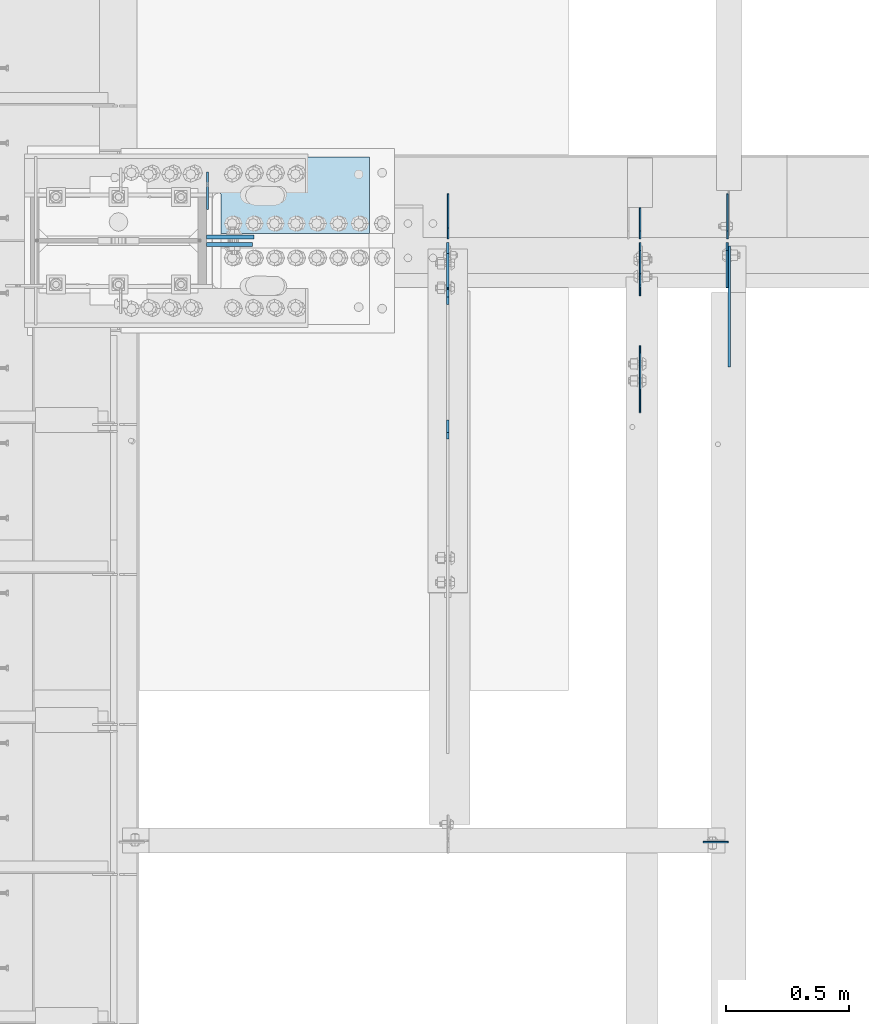
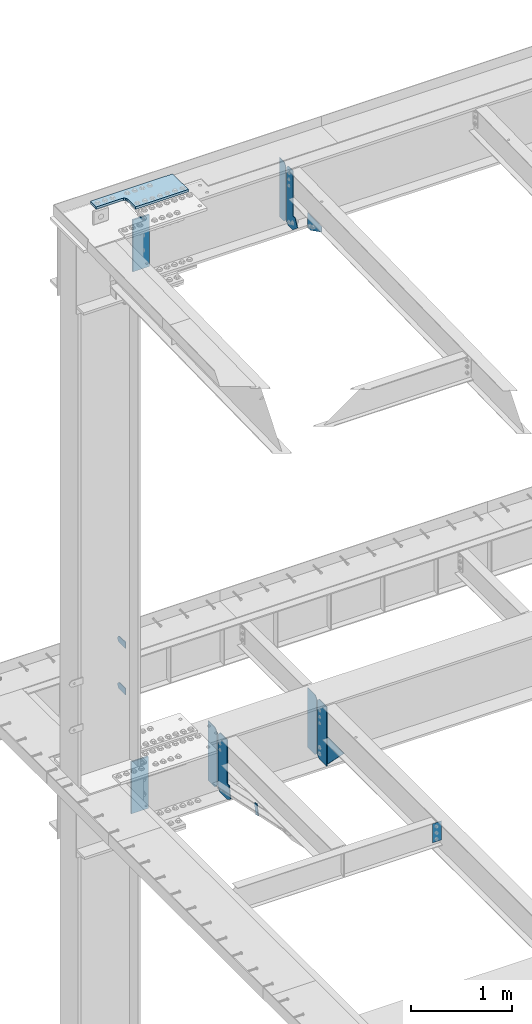
# One storey, part 1597 of 1763: 15 plates, 7 elements without a shape of their own.
"""IFC2X3 building model written with IfcOpenShell, lengths in millimetres."""

from ifc_helpers import new_model, si_unit, frame, origin_with_axes, place, context, subcontext, project, spatial, faceted_brep, material, type_object, element, aggregate, save


model = new_model("IFC2X3")

# Units and contexts
model_context = context("Model", 3, precision=1e-05, world=origin_with_axes())
body_context = subcontext(model_context, "Body", "Model", "MODEL_VIEW")
ifc_project = project(units=[si_unit("LENGTHUNIT", "METRE", prefix="MILLI"), si_unit("AREAUNIT", "SQUARE_METRE"), si_unit("VOLUMEUNIT", "CUBIC_METRE"), si_unit("MASSUNIT", "GRAM", prefix="KILO"), si_unit("TIMEUNIT", "SECOND"), si_unit("PLANEANGLEUNIT", "RADIAN"), si_unit("SOLIDANGLEUNIT", "STERADIAN"), si_unit("THERMODYNAMICTEMPERATUREUNIT", "DEGREE_CELSIUS"), si_unit("LUMINOUSINTENSITYUNIT", "LUMEN")], contexts=[model_context])

# Site, building, storey
site_placement = place(None, origin_with_axes())
site = spatial("IfcSite", under=ifc_project, at=site_placement, CompositionType="ELEMENT")
building_placement = place(site_placement, origin_with_axes())
building = spatial("IfcBuilding", under=site, at=building_placement, Name="Undefined", CompositionType="ELEMENT")
storey_placement = place(building_placement, origin_with_axes())
storey = spatial("IfcBuildingStorey", under=building, at=storey_placement, Name="Undefined", CompositionType="ELEMENT", Elevation=0.0)

# Assembly, plates
assembly_1_placement = place(storey_placement, origin_with_axes())
assembly_1 = element("IfcElementAssembly", 1, at=assembly_1_placement, inside=storey, Name="COLUMN", AssemblyPlace="NOTDEFINED", PredefinedType="RIGID_FRAME")
ifc_material_1 = material(Name="STEEL/A36")
plate_type_1 = type_object("IfcPlateType", PredefinedType="NOTDEFINED")
plate_1_placement = place(assembly_1_placement, frame((-87013.4872736984, 52247.8, 6489.69999847412), z_axis=(0.0, 0.0, -1.0), x_axis=(0.0, 1.0, 0.0)))
plate_1 = element("IfcPlate", 2, at=plate_1_placement, type_object=plate_type_1, material=ifc_material_1, Name="PLATE", context=body_context, shape_type="Brep", body=[
    faceted_brep([(0.0, -4.76249999999982, 0.0), (0.0, -4.76250000000073, 76.1999969482422), (0.0, 4.76250000000073, 76.1999969482422), (0.0, 4.76249999999982, 0.0), (114.299995422363, -4.76250000000073, 76.1999969482422), (114.299995422363, 4.76250000000073, 76.1999969482422), (126.073542436527, -4.76250000000073, 74.3352502937696), (126.073542436527, 4.76250000000073, 74.3352502937696), (136.694612637817, -4.76250000000073, 68.923544725345), (136.694612637817, 4.76250000000073, 68.923544725345), (145.123541673587, -4.76250000000073, 60.4946156895749), (145.123541673587, 4.76250000000073, 60.4946156895749), (150.535247242013, -4.76250000000073, 49.8735454882844), (150.535247242013, 4.76250000000073, 49.8735454882844), (152.399993896484, -4.76250000000073, 38.0999984741211), (152.399993896484, 4.76250000000073, 38.0999984741211), (150.535247242013, -4.76250000000073, 26.3264514599578), (150.535247242013, 4.76250000000073, 26.3264514599578), (145.123541673587, -4.76250000000073, 15.7053812586673), (145.123541673587, 4.76250000000073, 15.7053812586673), (136.694612637817, -4.76250000000073, 7.27645222289721), (136.694612637817, 4.76250000000073, 7.27645222289721), (126.073542436527, -4.76250000000073, 1.86474665447258), (126.073542436527, 4.76250000000073, 1.86474665447258), (114.299995422363, -4.76250000000073, 0.0), (114.299995422363, 4.76250000000073, 0.0)], [[[0, 1, 2, 3]], [[1, 4, 5, 2]], [[4, 6, 7, 5]], [[6, 8, 9, 7]], [[8, 10, 11, 9]], [[10, 12, 13, 11]], [[12, 14, 15, 13]], [[14, 16, 17, 15]], [[16, 18, 19, 17]], [[18, 20, 21, 19]], [[20, 22, 23, 21]], [[22, 24, 25, 23]], [[24, 0, 3, 25]], [[5, 7, 9, 11, 13, 15, 17, 19, 21, 23, 25, 3, 2]], [[24, 22, 20, 18, 16, 14, 12, 10, 8, 6, 4, 1, 0]]]),
])
plate_2_placement = place(assembly_1_placement, frame((-87013.4872736984, 52247.8, 5930.89999847412), z_axis=(0.0, 0.0, -1.0), x_axis=(0.0, 1.0, 0.0)))
plate_2 = element("IfcPlate", 3, at=plate_2_placement, type_object=plate_type_1, material=ifc_material_1, Name="PLATE", context=body_context, shape_type="Brep", body=[
    faceted_brep([(0.0, -4.76249999999982, 0.0), (0.0, -4.76250000000073, 76.1999969482422), (0.0, 4.76250000000073, 76.1999969482422), (0.0, 4.76249999999982, 0.0), (114.299995422363, -4.76250000000073, 76.1999969482422), (114.299995422363, 4.76250000000073, 76.1999969482422), (126.073542436527, -4.76250000000073, 74.3352502937696), (126.073542436527, 4.76250000000073, 74.3352502937696), (136.694612637817, -4.76250000000073, 68.923544725345), (136.694612637817, 4.76250000000073, 68.923544725345), (145.123541673587, -4.76250000000073, 60.4946156895749), (145.123541673587, 4.76250000000073, 60.4946156895749), (150.535247242013, -4.76250000000073, 49.8735454882844), (150.535247242013, 4.76250000000073, 49.8735454882844), (152.399993896484, -4.76250000000073, 38.0999984741211), (152.399993896484, 4.76250000000073, 38.0999984741211), (150.535247242013, -4.76250000000073, 26.3264514599578), (150.535247242013, 4.76250000000073, 26.3264514599578), (145.123541673587, -4.76250000000073, 15.7053812586673), (145.123541673587, 4.76250000000073, 15.7053812586673), (136.694612637817, -4.76250000000073, 7.27645222289721), (136.694612637817, 4.76250000000073, 7.27645222289721), (126.073542436527, -4.76250000000073, 1.86474665447258), (126.073542436527, 4.76250000000073, 1.86474665447258), (114.299995422363, -4.76250000000073, 0.0), (114.299995422363, 4.76250000000073, 0.0)], [[[0, 1, 2, 3]], [[1, 4, 5, 2]], [[4, 6, 7, 5]], [[6, 8, 9, 7]], [[8, 10, 11, 9]], [[10, 12, 13, 11]], [[12, 14, 15, 13]], [[14, 16, 17, 15]], [[16, 18, 19, 17]], [[18, 20, 21, 19]], [[20, 22, 23, 21]], [[22, 24, 25, 23]], [[24, 0, 3, 25]], [[5, 7, 9, 11, 13, 15, 17, 19, 21, 23, 25, 3, 2]], [[24, 22, 20, 18, 16, 14, 12, 10, 8, 6, 4, 1, 0]]]),
])

# Assembly, plate
assembly_2_placement = place(storey_placement, origin_with_axes())
assembly_2 = element("IfcElementAssembly", 4, at=assembly_2_placement, inside=storey, Name="ANGLE BRACE", AssemblyPlace="NOTDEFINED", PredefinedType="RIGID_FRAME")
plate_type_2 = type_object("IfcPlateType", PredefinedType="NOTDEFINED")
plate_3_placement = place(assembly_2_placement, frame((-86037.1747736983, 51342.4281032895, 4746.91590772782), z_axis=(0.0, -0.208168683014592, -0.978092940068566), x_axis=(0.0, 0.978092940068566, -0.208168683014588)))
plate_3 = element("IfcPlate", 5, at=plate_3_placement, type_object=plate_type_2, material=ifc_material_1, Name="PLATE", context=body_context, shape_type="Brep", body=[
    faceted_brep([(0.0, -4.76249999999982, 0.0), (2.11002770811319e-09, -4.76249999999709, 127.040328979458), (2.11002770811319e-09, 4.76249999999709, 127.040328979458), (0.0, 4.76249999999982, 0.0), (50.7119293213109, -4.76249999999709, 126.999992370584), (50.7119293213109, 4.76249999999709, 126.999992370584), (50.7119293211581, -4.76249999999709, 1.63709046319127e-11), (50.7119293211581, 4.76249999999709, 1.63709046319127e-11)], [[[0, 1, 2, 3]], [[1, 4, 5, 2]], [[4, 6, 7, 5]], [[6, 0, 3, 7]], [[5, 7, 3, 2]], [[6, 4, 1, 0]]]),
])
aggregate(assembly_2, [plate_3])

assembly_3_placement = place(storey_placement, origin_with_axes())
assembly_3 = element("IfcElementAssembly", 6, at=assembly_3_placement, inside=storey, Name="BEAM", AssemblyPlace="NOTDEFINED", PredefinedType="RIGID_FRAME")
plate_type_3 = type_object("IfcPlateType", PredefinedType="NOTDEFINED")
plate_4_placement = place(assembly_3_placement, frame((-84897.878940365, 49676.84375, 5156.2), z_axis=(-1.0, 0.0, 0.0), x_axis=(0.0, 0.0, -1.0)))
plate_4 = element("IfcPlate", 7, at=plate_4_placement, type_object=plate_type_3, material=ifc_material_1, Name="PLATE", context=body_context, shape_type="Brep", body=[
    faceted_brep([(1.81898940354586e-12, -3.17500000000291, 0.0), (0.0, -3.17499999999927, 101.599998474121), (0.0, 3.17499999999927, 101.599998474121), (-1.81898940354586e-12, 3.17499999997381, 0.0), (228.600006103516, -3.17499999999927, 101.599998474121), (228.600006103516, 3.17499999999927, 101.599998474121), (228.600006103516, -3.17500000001019, -7.27595761418343e-12), (228.600006103516, 3.17499999999563, -7.27595761418343e-12)], [[[0, 1, 2, 3]], [[1, 4, 5, 2]], [[4, 6, 7, 5]], [[6, 0, 3, 7]], [[5, 7, 3, 2]], [[6, 4, 1, 0]]]),
])

assembly_4_placement = place(storey_placement, origin_with_axes())
assembly_4 = element("IfcElementAssembly", 8, at=assembly_4_placement, inside=storey, Name="BEAM", AssemblyPlace="NOTDEFINED", PredefinedType="RIGID_FRAME")
plate_type_4 = type_object("IfcPlateType", PredefinedType="NOTDEFINED")
plate_5_placement = place(assembly_4_placement, frame((-85255.4444166032, 52128.7375017387, 11001.3749917654), z_axis=(0.0, 0.0, 1.0), x_axis=(0.0, 1.0, 0.0)))
plate_5 = element("IfcPlate", 9, at=plate_5_placement, type_object=plate_type_4, material=ifc_material_1, Name="PLATE", context=body_context, shape_type="Brep", body=[
    faceted_brep([(0.0, -3.17500000000291, 31.75), (0.0, -3.17500000000291, 682.625), (0.0, 3.17500000000291, 682.625), (0.0, 3.17500000000291, 31.75), (31.75, -3.17500000000291, 714.375), (31.75, 3.17500000000291, 714.375), (125.412498474121, -3.17500000000291, 714.375), (125.412498474121, 3.17500000000291, 714.375), (125.412498474121, -3.17500000000291, 0.0), (125.412498474121, 3.17500000000291, 0.0), (31.7499999999036, -3.17499999997381, 9.42916855706244e-11), (31.7499999998854, 3.17500000000291, 9.42916855706244e-11)], [[[0, 1, 2, 3]], [[1, 4, 5, 2]], [[4, 6, 7, 5]], [[6, 8, 9, 7]], [[8, 10, 11, 9]], [[10, 0, 3, 11]], [[5, 7, 9, 11, 3, 2]], [[10, 8, 6, 4, 1, 0]]]),
])

# Assembly, plates
assembly_5_placement = place(storey_placement, origin_with_axes())
assembly_5 = element("IfcElementAssembly", 10, at=assembly_5_placement, inside=storey, Name="BEAM", AssemblyPlace="NOTDEFINED", PredefinedType="RIGID_FRAME")
plate_type_5 = type_object("IfcPlateType", PredefinedType="NOTDEFINED")
plate_6_placement = place(assembly_5_placement, frame((-84901.0539404127, 52128.7375, 4448.175), z_axis=(0.0, 0.0, 1.0), x_axis=(0.0, 1.0, 0.0)))
plate_6 = element("IfcPlate", 11, at=plate_6_placement, type_object=plate_type_5, material=ifc_material_1, Name="PLATE", context=body_context, shape_type="Brep", body=[
    faceted_brep([(0.0, -3.17500000000291, 31.75), (0.0, -3.17500000000291, 687.387512207031), (0.0, 3.17500000000291, 687.387512207031), (0.0, 3.17500000000291, 31.75), (31.75, -3.17500000000291, 719.137512207031), (31.75, 3.17500000000291, 719.137512207031), (182.5625, -3.17500000000291, 719.137512207031), (182.5625, 3.17500000000291, 719.137512207031), (182.5625, -3.17500000000291, 0.0), (182.5625, 3.17500000000291, 0.0), (31.7499999999036, -3.17499999997381, 9.42916855706244e-11), (31.7499999998854, 3.17500000000291, 9.42916855706244e-11)], [[[0, 1, 2, 3]], [[1, 4, 5, 2]], [[4, 6, 7, 5]], [[6, 8, 9, 7]], [[8, 10, 11, 9]], [[10, 0, 3, 11]], [[5, 7, 9, 11, 3, 2]], [[10, 8, 6, 4, 1, 0]]]),
])
plate_7_placement = place(assembly_5_placement, frame((-86035.587273746, 52128.7375, 4448.175), z_axis=(0.0, 0.0, 1.0), x_axis=(0.0, 1.0, 0.0)))
plate_7 = element("IfcPlate", 12, at=plate_7_placement, type_object=plate_type_5, material=ifc_material_1, Name="PLATE", context=body_context, shape_type="Brep", body=[
    faceted_brep([(0.0, -3.17500000000291, 44.4500000000007), (0.0, -3.17500000000291, 673.099987030029), (0.0, 3.17500000000291, 673.099987030029), (0.0, 3.17500000000291, 44.4500000000007), (44.4500007629395, -3.17500000000291, 717.549987792969), (44.4500007629395, 3.17500000000291, 717.549987792969), (182.5625, -3.17500000000291, 717.549987792969), (182.5625, 3.17500000000291, 717.549987792969), (182.5625, -3.17500000000291, 0.0), (182.5625, 3.17500000000291, 0.0), (44.4500007629395, -3.17500000000291, 0.0), (44.4500007629395, 3.17500000000291, 0.0)], [[[0, 1, 2, 3]], [[1, 4, 5, 2]], [[4, 6, 7, 5]], [[6, 8, 9, 7]], [[8, 10, 11, 9]], [[10, 0, 3, 11]], [[5, 7, 9, 11, 3, 2]], [[10, 8, 6, 4, 1, 0]]]),
])
plate_type_6 = type_object("IfcPlateType", PredefinedType="NOTDEFINED")
plate_8_placement = place(assembly_5_placement, frame((-84901.8486904299, 52112.8625, 4448.175), z_axis=(0.0, 0.0, 1.0), x_axis=(0.0, -1.0, 0.0)))
plate_8 = element("IfcPlate", 13, at=plate_8_placement, type_object=plate_type_6, material=ifc_material_1, Name="PLATE", context=body_context, shape_type="Brep", body=[
    faceted_brep([(0.0, -3.96899999999732, 31.75), (0.0, -3.96899999999732, 687.387512207031), (0.0, 3.96899999999732, 687.387512207031), (0.0, 3.96899999999732, 31.75), (31.75, -3.96899999999732, 719.137512207031), (31.75, 3.96899999999732, 719.137512207031), (182.5625, -3.96899999999732, 719.137512207031), (182.5625, 3.96899999999732, 719.137512207031), (182.5625, -3.96899999999732, 0.0), (182.5625, 3.96899999999732, 0.0), (31.75, -3.96899999999732, 0.0), (31.75, 3.96899999999732, 0.0)], [[[0, 1, 2, 3]], [[1, 4, 5, 2]], [[4, 6, 7, 5]], [[6, 8, 9, 7]], [[8, 10, 11, 9]], [[10, 0, 3, 11]], [[5, 7, 9, 11, 3, 2]], [[10, 8, 6, 4, 1, 0]]]),
])

# Plate
plate_type_7 = type_object("IfcPlateType", PredefinedType="NOTDEFINED")
plate_9_placement = place(assembly_3_placement, frame((-84893.1164404127, 51930.3004272461, 4794.2499684514), z_axis=(0.0, 0.0, -1.0), x_axis=(0.0, -1.0, 0.0)))
plate_9 = element("IfcPlate", 14, at=plate_9_placement, type_object=plate_type_7, material=ifc_material_1, Name="PLATE", context=body_context, shape_type="Brep", body=[
    faceted_brep([(0.0, -4.76249999999982, 0.0), (-169.862075805664, -4.76249999999709, 6.30279828328639e-10), (-169.862075805664, 4.76249999999709, 6.30279828328639e-10), (0.0, 4.76249999999982, 0.0), (-169.862091064453, -4.76249999999709, 323.002471923828), (-169.862091064453, 4.76249999999709, 323.002471923828), (6.38101482763886e-09, -4.76249999999709, 323.002471923828), (6.38101482763886e-09, 4.76249999999709, 323.002471923828), (322.262145996094, -4.76249999999709, -1.15778675535694e-09), (322.262145996094, 4.76249999999709, -1.15778675535694e-09)], [[[0, 1, 2, 3]], [[1, 4, 5, 2]], [[4, 6, 7, 5]], [[6, 8, 9, 7]], [[8, 0, 3, 9]], [[5, 7, 9, 3, 2]], [[8, 6, 4, 1, 0]]]),
])

aggregate(assembly_3, [plate_9, plate_4])

ifc_material_2 = material(Name="STEEL/A572-50")
plate_type_8 = type_object("IfcPlateType", PredefinedType="NOTDEFINED")
plate_10_placement = place(assembly_1_placement, frame((-86830.9247736984, 52104.9250002128, 11045.8249917654), z_axis=(-1.0, 0.0, 0.0), x_axis=(0.0, 0.0, 1.0)))
plate_10 = element("IfcPlate", 15, at=plate_10_placement, type_object=plate_type_8, material=ifc_material_2, Name="SHEAR TAB", context=body_context, shape_type="Brep", body=[
    faceted_brep([(-7.27595761418343e-12, -7.9375, 0.0), (0.0, -7.9375, 187.324996948242), (0.0, 7.9375, 187.324996948242), (-7.27595761418343e-12, 7.9375, 0.0), (625.474975585938, -7.9375, 187.324996948242), (625.474975585938, 7.9375, 187.324996948242), (625.474975585938, -7.9375, 0.0), (625.474975585938, 7.9375, 0.0)], [[[0, 1, 2, 3]], [[1, 4, 5, 2]], [[4, 6, 7, 5]], [[6, 0, 3, 7]], [[5, 7, 3, 2]], [[6, 4, 1, 0]]]),
])

# Assembly, plate
assembly_6_placement = place(storey_placement, origin_with_axes())
assembly_6 = element("IfcElementAssembly", 16, at=assembly_6_placement, inside=storey, Name="TOP PLATE", AssemblyPlace="NOTDEFINED", PredefinedType="RIGID_FRAME")
plate_type_9 = type_object("IfcPlateType", PredefinedType="NOTDEFINED")
plate_11_placement = place(assembly_6_placement, frame((-86957.9247736984, 52149.3750002128, 11761.7874917654), z_axis=(0.0, 1.0, 0.0), x_axis=(1.0, 0.0, 0.0)))
plate_11 = element("IfcPlate", 17, at=plate_11_placement, type_object=plate_type_9, material=ifc_material_2, Name="TOP PLATE", context=body_context, shape_type="Brep", body=[
    faceted_brep([(0.0, -14.2875000000058, 0.0), (0.0, -14.2875000000004, 152.400001525879), (0.0, 14.2875000000004, 152.400001525879), (0.0, 14.2875000000058, 0.0), (-3.14187241174659, -14.2875000000004, 168.195260780674), (-3.14187241174659, 14.2875000000004, 168.195260780674), (-12.0891680534478, -14.2875000000004, 181.58583499831), (-12.0891680534478, 14.2875000000004, 181.58583499831), (-25.4797422710835, -14.2875000000004, 190.533130640011), (-25.4797422710835, 14.2875000000004, 190.533130640011), (-41.2750015258789, -14.2875000000004, 193.675003051758), (-41.2750015258789, 14.2875000000004, 193.675003051758), (-336.549987792969, -14.2875000000004, 193.675003051758), (-336.549987792969, 14.2875000000004, 193.675003051758), (-336.549987792969, -14.2875000000004, 311.149993896484), (-336.549987792969, 14.2875000000004, 311.149993896484), (603.25, -14.2875000000004, 311.149993896484), (603.25, 14.2875000000004, 311.149993896484), (603.25, -14.2875000000004, 0.0), (603.25, 14.2875000000004, 0.0)], [[[0, 1, 2, 3]], [[1, 4, 5, 2]], [[4, 6, 7, 5]], [[6, 8, 9, 7]], [[8, 10, 11, 9]], [[10, 12, 13, 11]], [[12, 14, 15, 13]], [[14, 16, 17, 15]], [[16, 18, 19, 17]], [[18, 0, 3, 19]], [[5, 7, 9, 11, 13, 15, 17, 19, 3, 2]], [[18, 16, 14, 12, 10, 8, 6, 4, 1, 0]]]),
])
aggregate(assembly_6, [plate_11])

# Plate
plate_type_10 = type_object("IfcPlateType", PredefinedType="NOTDEFINED")
plate_12_placement = place(assembly_1_placement, frame((-86824.5747736983, 52136.675, 4494.2125), z_axis=(-1.0, 0.0, 0.0), x_axis=(0.0, 0.0, 1.0)))
plate_12 = element("IfcPlate", 18, at=plate_12_placement, type_object=plate_type_10, material=ifc_material_2, Name="SHEAR TAB", context=body_context, shape_type="Brep", body=[
    faceted_brep([(-7.27595761418343e-12, -7.9375, 0.0), (0.0, -7.9375, 193.675003051758), (0.0, 7.9375, 193.675003051758), (-7.27595761418343e-12, 7.9375, 0.0), (625.474975585938, -7.9375, 193.675003051758), (625.474975585938, 7.9375, 193.675003051758), (625.474975585938, -7.9375, 0.0), (625.474975585938, 7.9375, 0.0)], [[[0, 1, 2, 3]], [[1, 4, 5, 2]], [[4, 6, 7, 5]], [[6, 0, 3, 7]], [[5, 7, 3, 2]], [[6, 4, 1, 0]]]),
])

aggregate(assembly_1, [plate_1, plate_2, plate_10, plate_12])

# Assembly, plate
assembly_7_placement = place(storey_placement, origin_with_axes())
assembly_7 = element("IfcElementAssembly", 19, at=assembly_7_placement, inside=storey, Name="BEAM", AssemblyPlace="NOTDEFINED", PredefinedType="RIGID_FRAME")
plate_type_11 = type_object("IfcPlateType", PredefinedType="NOTDEFINED")
plate_13_placement = place(assembly_7_placement, frame((-85255.5493333491, 51694.7966838135, 11389.3613879076), z_axis=(0.0, 0.0206852279954837, -0.999786037781472), x_axis=(0.0, -0.999786037781472, -0.0206852279954809)))
plate_13 = element("IfcPlate", 20, at=plate_13_placement, type_object=plate_type_11, material=ifc_material_1, Name="PLATE", context=body_context, shape_type="Brep", body=[
    faceted_brep([(1.81898940354586e-12, -3.17500000000291, 0.0), (3.65093994144991, -3.17500000000291, 176.462081909045), (3.65093994144991, 3.17500000000291, 176.462081909045), (-1.81898940354586e-12, 3.17499999997381, 0.0), (66.5735244753159, -3.17500000000291, 175.160232543794), (66.5735244753159, 3.17500000000291, 175.160232543794), (272.493255616027, -3.17500000000291, 66.8189620970425), (272.493255616027, 3.17500000000291, 66.8189620970425), (272.493255616013, -3.17500000000291, -3.03771230392158e-10), (272.493255616013, 3.17500000000291, -3.03771230392158e-10)], [[[0, 1, 2, 3]], [[1, 4, 5, 2]], [[4, 6, 7, 5]], [[6, 8, 9, 7]], [[8, 0, 3, 9]], [[5, 7, 9, 3, 2]], [[8, 6, 4, 1, 0]]]),
])
aggregate(assembly_7, [plate_13])

# Plate
plate_type_12 = type_object("IfcPlateType", PredefinedType="NOTDEFINED")
plate_14_placement = place(assembly_4_placement, frame((-85255.4444166032, 52112.8625017387, 11001.3750039724), z_axis=(0.0, 0.0, 1.0), x_axis=(0.0, -1.0, 0.0)))
plate_14 = element("IfcPlate", 21, at=plate_14_placement, type_object=plate_type_12, material=ifc_material_1, Name="PLATE", context=body_context, shape_type="Brep", body=[
    faceted_brep([(0.0, -3.17500000000291, 31.75), (0.0, -3.17500000000291, 682.625), (0.0, 3.17500000000291, 682.625), (0.0, 3.17500000000291, 31.75), (31.75, -3.17500000000291, 714.375), (31.75, 3.17500000000291, 714.375), (125.412498474121, -3.17500000000291, 714.375), (125.412498474121, 3.17500000000291, 714.375), (125.412498474121, -3.17500000000291, 170.178436279297), (125.412498474121, 3.17500000000291, 170.178436279297), (171.201705932617, -3.17500000000291, 170.178436279297), (171.201705932617, 3.17500000000291, 170.178436279297), (216.638702392578, -3.17500000000291, 79.3046722412109), (216.638702392578, 3.17500000000291, 79.3046722412109), (125.412498474121, -3.17500000000291, 0.0), (125.412498474121, 3.17500000000291, 0.0), (31.7499999999036, -3.17499999997381, 9.42916855706244e-11), (31.7499999998854, 3.17500000000291, 9.42916855706244e-11)], [[[0, 1, 2, 3]], [[1, 4, 5, 2]], [[4, 6, 7, 5]], [[6, 8, 9, 7]], [[8, 10, 11, 9]], [[10, 12, 13, 11]], [[12, 14, 15, 13]], [[14, 16, 17, 15]], [[16, 0, 3, 17]], [[5, 7, 9, 11, 13, 15, 17, 3, 2]], [[16, 14, 12, 10, 8, 6, 4, 1, 0]]]),
])

aggregate(assembly_4, [plate_5, plate_14])

plate_type_13 = type_object("IfcPlateType", PredefinedType="NOTDEFINED")
plate_15_placement = place(assembly_5_placement, frame((-86037.174773746, 52112.8625, 4448.175), z_axis=(0.0, 0.0, 1.0), x_axis=(0.0, -1.0, 0.0)))
plate_15 = element("IfcPlate", 22, at=plate_15_placement, type_object=plate_type_13, material=ifc_material_1, Name="PLATE", context=body_context, shape_type="Brep", body=[
    faceted_brep([(-8.03411239758134e-08, -4.76249999999709, 44.4500007629395), (-1.21945049613714e-06, -4.76249999999709, 674.687450408936), (-1.21945049613714e-06, 4.76249999999709, 674.687450408936), (-8.03411239758134e-08, 4.76249999999709, 44.4500007629395), (44.4499994631478, -4.76249999999709, 719.137436311141), (44.4499994631478, 4.76249999999709, 719.137436311141), (182.5625, -4.76249999999709, 719.137390136719), (182.5625, 4.76249999999709, 719.137390136719), (182.5625, -4.76249999999709, 201.622897148132), (182.5625, 4.76249999999709, 201.622897148132), (183.529229922591, -4.76249999999709, 196.762817630087), (183.529229922591, 4.76249999999709, 196.762817630087), (186.282243823065, -4.76249999999709, 192.642641161933), (186.282243823065, 4.76249999999709, 192.642641161933), (190.402420291219, -4.76249999999709, 189.889627261455), (190.402420291219, 4.76249999999709, 189.889627261455), (195.262499809265, -4.76249999999709, 188.922897338867), (195.262499809265, 4.76249999999709, 188.922897338867), (219.799514770508, -4.76249999999709, 188.922897338867), (219.799514770508, 4.76249999999709, 188.922897338867), (250.737014770508, -4.76249999999709, 42.4546127319336), (250.737014770508, 4.76249999999709, 42.4546127319336), (182.5625, -4.76249999999709, -3.63797880709171e-12), (182.5625, 4.76249999999709, -3.63797880709171e-12), (44.4500007629395, -4.76249999999709, 0.0), (44.4500007629395, 4.76249999999709, 0.0)], [[[0, 1, 2, 3]], [[1, 4, 5, 2]], [[4, 6, 7, 5]], [[6, 8, 9, 7]], [[8, 10, 11, 9]], [[10, 12, 13, 11]], [[12, 14, 15, 13]], [[14, 16, 17, 15]], [[16, 18, 19, 17]], [[18, 20, 21, 19]], [[20, 22, 23, 21]], [[22, 24, 25, 23]], [[24, 0, 3, 25]], [[5, 7, 9, 11, 13, 15, 17, 19, 21, 23, 25, 3, 2]], [[24, 22, 20, 18, 16, 14, 12, 10, 8, 6, 4, 1, 0]]]),
])

aggregate(assembly_5, [plate_6, plate_8, plate_7, plate_15])

save(model, "model.ifc")
